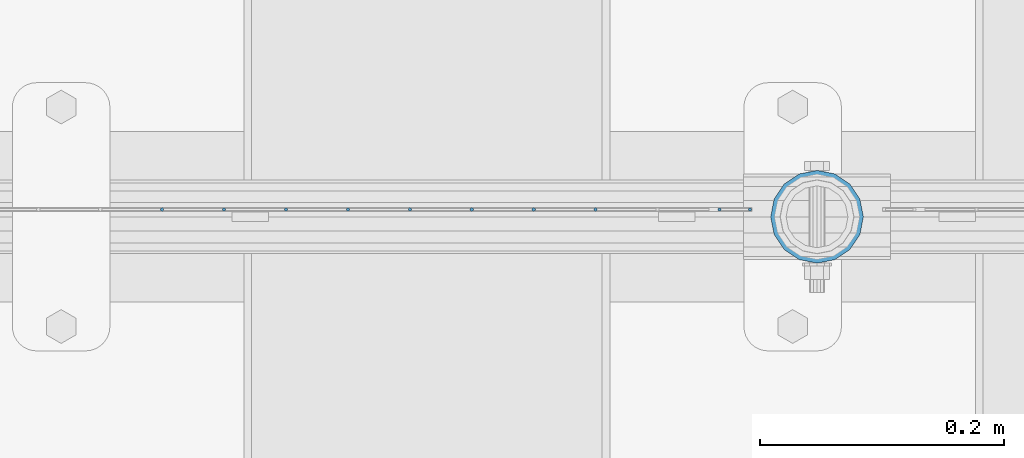
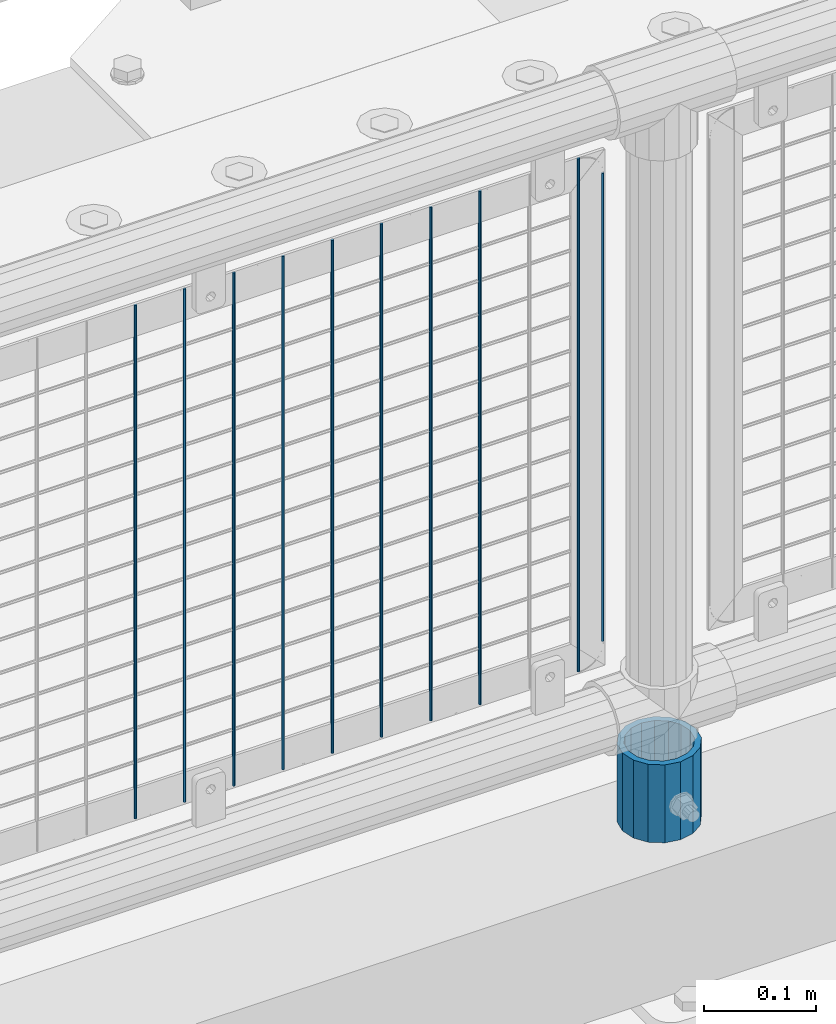
# One storey, part 73 of 242: 11 columns.
"""IFC2X3 building model written with IfcOpenShell, lengths in millimetres."""

import ifcopenshell
import ifcopenshell.guid

model = None  # the IFC model being written
_history = None  # IfcOwnerHistory: only IFC2X3 demands one
_inside = {}  # id of a spatial element -> (the spatial element, [elements in it])
_under = {}  # id of a project, library or spatial element -> (it, [spatial elements below it])
_declared = {}  # id of a project -> (the project, [libraries it declares])
_typed = {}  # id of a type object -> (the type object, [elements of that type])
_made_of = {}  # id of a material, layer set ... -> (it, [elements and type objects made of it])


def new_model(schema):
    """Start an empty IFC model of exactly this schema.

    Asked for "IFC4X3", IfcOpenShell would pick the latest addendum, in which some entities
    have other attributes; the version numbers below select the first issue.
    IFC2X3 requires an IfcOwnerHistory on every rooted entity: one is made here for all.
    """
    global model, _history
    if schema == "IFC4X3":
        model = ifcopenshell.file(schema_version=(4, 3, 0, 0))
    else:
        model = ifcopenshell.file(schema=schema)
    _inside.clear()
    _under.clear()
    _declared.clear()
    _typed.clear()
    _made_of.clear()
    _history = None
    if model.schema == "IFC2X3":
        org = make("IfcOrganization", Name="unknown")
        user = make(
            "IfcPersonAndOrganization",
            ThePerson=make("IfcPerson", FamilyName="unknown"),
            TheOrganization=org,
        )
        app = make(
            "IfcApplication",
            ApplicationDeveloper=org,
            Version="unknown",
            ApplicationFullName="unknown",
            ApplicationIdentifier="unknown",
        )
        _history = make(
            "IfcOwnerHistory",
            OwningUser=user,
            OwningApplication=app,
            ChangeAction="ADDED",
            CreationDate=0,
        )
    return model


def make(cls, **values):
    """One entity of the class cls with the attributes given. An attribute that is None is left unset."""
    return model.create_entity(
        cls, **{name: value for name, value in values.items() if value is not None}
    )


def rooted(cls, **values):
    """An entity with a GlobalId (a new one), such as an element, a storey or a relation."""
    return make(cls, GlobalId=ifcopenshell.guid.new(), OwnerHistory=_history, **values)


def si_unit(unit_type, name, prefix=None):
    """IfcSIUnit, for example si_unit("LENGTHUNIT", "METRE", prefix="MILLI")."""
    return make("IfcSIUnit", UnitType=unit_type, Prefix=prefix, Name=name)


def assignment(units):
    """IfcUnitAssignment: the units of a project."""
    return None if units is None else make("IfcUnitAssignment", Units=units)


def point(xyz):
    """IfcCartesianPoint."""
    return None if xyz is None else make("IfcCartesianPoint", Coordinates=xyz)


def direction(xyz):
    """IfcDirection."""
    return None if xyz is None else make("IfcDirection", DirectionRatios=xyz)


def frame(location, z_axis=None, x_axis=None):
    """IfcAxis2Placement3D, a coordinate frame: its origin and axes. An axis left out is left unset."""
    return make(
        "IfcAxis2Placement3D",
        Location=point(location),
        Axis=direction(z_axis),
        RefDirection=direction(x_axis),
    )


def origin_with_axes():
    """The frame at (0, 0, 0) with the z axis (0, 0, 1) and the x axis (1, 0, 0) written out."""
    return frame((0.0, 0.0, 0.0), z_axis=(0.0, 0.0, 1.0), x_axis=(1.0, 0.0, 0.0))


def place(relative_to, where):
    """IfcLocalPlacement: puts the frame where relative to a parent placement (None: the world)."""
    return make(
        "IfcLocalPlacement", PlacementRelTo=relative_to, RelativePlacement=where
    )


def context(
    kind, dimensions, precision=None, world=None, true_north=None, identifier=None
):
    """IfcGeometricRepresentationContext, for example the 3D "Model" context."""
    return make(
        "IfcGeometricRepresentationContext",
        ContextIdentifier=identifier,
        ContextType=kind,
        CoordinateSpaceDimension=dimensions,
        Precision=precision,
        WorldCoordinateSystem=world,
        TrueNorth=true_north,
    )


def subcontext(parent, identifier, kind, view, scale=None):
    """IfcGeometricRepresentationSubContext, for example "Body" below "Model"."""
    return make(
        "IfcGeometricRepresentationSubContext",
        ContextIdentifier=identifier,
        ContextType=kind,
        ParentContext=parent,
        TargetScale=scale,
        TargetView=view,
    )


def project(units=None, contexts=None):
    """IfcProject with its units and contexts."""
    return rooted(
        "IfcProject",
        Name="project",
        RepresentationContexts=contexts,
        UnitsInContext=assignment(units),
    )


def spatial(cls, under=None, at=None, **own):
    """A site, building, storey or space (cls), placed at a placement, below another one or the project."""
    s = rooted(cls, ObjectPlacement=at, **own)
    if under is not None:
        _under.setdefault(under.id(), (under, []))[1].append(s)
    return s


def faces_of(points, faces, orient=None, outer=None):
    """IfcFace entities. A face is a list of loops; a loop is a list of indices into points, from 0.

    orient and outer hold one flag for each loop. By default every Orientation is true, the
    first loop of a face is its IfcFaceOuterBound and the others are IfcFaceBound.
    """
    made = []
    for i, loops in enumerate(faces):
        bounds = []
        for j, loop in enumerate(loops):
            is_outer = j == 0 if outer is None else outer[i][j]
            bounds.append(
                make(
                    "IfcFaceOuterBound" if is_outer else "IfcFaceBound",
                    Bound=make("IfcPolyLoop", Polygon=[points[k] for k in loop]),
                    Orientation=True if orient is None else orient[i][j],
                )
            )
        made.append(make("IfcFace", Bounds=bounds))
    return made


def faceted_brep(points, faces, orient=None, outer=None, voids=None):
    """IfcFacetedBrep: a solid bounded by flat faces; with voids (closed shells), ...WithVoids."""
    shared = [point(p) for p in points]
    hull = make("IfcClosedShell", CfsFaces=faces_of(shared, faces, orient, outer))
    if voids is None:
        return make("IfcFacetedBrep", Outer=hull)
    return make(
        "IfcFacetedBrepWithVoids",
        Outer=hull,
        Voids=[
            make(cls, CfsFaces=faces_of(shared, fs, o, b)) for cls, fs, o, b in voids
        ],
    )


def shape(context_of_items, identifier, shape_type, items):
    """IfcShapeRepresentation: the items that make up one representation, for example the "Body"."""
    return make(
        "IfcShapeRepresentation",
        ContextOfItems=context_of_items,
        RepresentationIdentifier=identifier,
        RepresentationType=shape_type,
        Items=items,
    )


def material(Name=None, Category=None):
    """IfcMaterial."""
    return make("IfcMaterial", Name=Name, Category=Category)


def made_of(thing, what):
    """Note that an element or type object is made of a material, layer set ...; save() writes the relation."""
    if what is not None:
        _made_of.setdefault(what.id(), (what, []))[1].append(thing)
    return thing


def type_object(cls, material=None, **own):
    """A type object (cls), such as IfcWallType, which elements share."""
    return made_of(rooted(cls, **own), material)


def element(
    cls,
    number,
    at=None,
    inside=None,
    cuts=None,
    type_object=None,
    material=None,
    context=None,
    identifier="Body",
    shape_type=None,
    held_by="IfcProductDefinitionShape",
    body=None,
    shapes=None,
    **own,
):
    """One element of the class cls, such as IfcWall. Its Tag is "e" and its number.

    at: its placement. inside: the storey or other place that contains it. cuts: it is an
    opening in that element (IfcRelVoidsElement). A single representation is given by context,
    identifier, shape_type and body (its items); several are given by shapes. held_by: the class
    of the entity that holds the representations. save() writes the other relations.
    """
    e = rooted(cls, Tag="e%d" % number, ObjectPlacement=at, **own)
    if body is not None:
        shapes = [shape(context, identifier, shape_type, body)]
    if shapes is not None:
        e.Representation = make(held_by, Representations=shapes)
    if inside is not None:
        _inside.setdefault(inside.id(), (inside, []))[1].append(e)
    if cuts is not None:
        rooted(
            "IfcRelVoidsElement", RelatingBuildingElement=cuts, RelatedOpeningElement=e
        )
    if type_object is not None:
        _typed.setdefault(type_object.id(), (type_object, []))[1].append(e)
    return made_of(e, material)


def aggregate(whole, parts):
    """IfcRelAggregates: a whole, such as a stair, and the parts it consists of."""
    return rooted("IfcRelAggregates", RelatingObject=whole, RelatedObjects=parts)


def save(model, path):
    """Write the relations noted so far, then the file.

    IfcRelAggregates (storeys below a building ...), IfcRelContainedInSpatialStructure (elements
    in a storey), IfcRelDefinesByType, IfcRelAssociatesMaterial and IfcRelDeclares: one each for
    every whole, place, type object, material and project.
    """
    for whole, parts in _under.values():
        aggregate(whole, parts)
    for where, things in _inside.values():
        rooted(
            "IfcRelContainedInSpatialStructure",
            RelatedElements=things,
            RelatingStructure=where,
        )
    for kind, things in _typed.values():
        rooted("IfcRelDefinesByType", RelatedObjects=things, RelatingType=kind)
    for what, things in _made_of.values():
        rooted("IfcRelAssociatesMaterial", RelatedObjects=things, RelatingMaterial=what)
    for by, libraries in _declared.values():
        rooted("IfcRelDeclares", RelatingContext=by, RelatedDefinitions=libraries)
    model.write(path)


model = new_model("IFC2X3")

# Units and contexts
model_context = context("Model", 3, precision=1e-05, world=origin_with_axes())
body_context = subcontext(model_context, "Body", "Model", "MODEL_VIEW")
ifc_project = project(units=[si_unit("LENGTHUNIT", "METRE", prefix="MILLI"), si_unit("AREAUNIT", "SQUARE_METRE"), si_unit("VOLUMEUNIT", "CUBIC_METRE"), si_unit("MASSUNIT", "GRAM", prefix="KILO"), si_unit("TIMEUNIT", "SECOND"), si_unit("PLANEANGLEUNIT", "RADIAN"), si_unit("SOLIDANGLEUNIT", "STERADIAN"), si_unit("THERMODYNAMICTEMPERATUREUNIT", "DEGREE_CELSIUS"), si_unit("LUMINOUSINTENSITYUNIT", "LUMEN")], contexts=[model_context])

# Site, building, storey
site_placement = place(None, origin_with_axes())
site = spatial("IfcSite", under=ifc_project, at=site_placement, CompositionType="ELEMENT")
building_placement = place(site_placement, origin_with_axes())
building = spatial("IfcBuilding", under=site, at=building_placement, Name="Standard", CompositionType="ELEMENT")
storey_placement = place(building_placement, origin_with_axes())
storey = spatial("IfcBuildingStorey", under=building, at=storey_placement, Name="Undefined", CompositionType="ELEMENT", Elevation=0.0)

# Columns
ifc_material_1 = material(Name="Misc_Undefined")
column_type_1 = type_object("IfcColumnType", Name="D3", PredefinedType="NOTDEFINED")
for number, where, z_axis, x_axis in (
    (1, (-37111.589, -19329.5, 353.02), (-1.0, 0.0, 0.0), (0.0, 0.0, 1.0)),
    (2, (-37162.382, -19329.5, 353.02), (-1.0, 0.0, 0.0), (0.0, 0.0, 1.0)),
    (3, (-37213.175, -19329.5, 353.02), (-1.0, 0.0, 0.0), (0.0, 0.0, 1.0)),
    (4, (-37263.968, -19329.5, 353.02), (-1.0, 0.0, 0.0), (0.0, 0.0, 1.0)),
    (5, (-37314.761, -19329.5, 353.02), (-1.0, 0.0, 0.0), (0.0, 0.0, 1.0)),
    (6, (-37365.554, -19329.5, 353.02), (-1.0, 0.0, 0.0), (0.0, 0.0, 1.0)),
    (7, (-37010.003, -19329.5, 353.02), (-1.0, 0.0, 0.0), (0.0, 0.0, 1.0)),
    (8, (-37416.347, -19329.5, 353.02), (-1.0, 0.0, 0.0), (0.0, 0.0, 1.0)),
    (9, (-37467.14, -19329.5, 353.02), (-1.0, 0.0, 0.0), (0.0, 0.0, 1.0)),
):
    element("IfcColumn", number, at=place(storey_placement, frame(where, z_axis=z_axis, x_axis=x_axis)), inside=storey, type_object=column_type_1, material=ifc_material_1, ObjectType="D3", context=body_context, shape_type="Brep", body=[
        faceted_brep([(0.0, -1.50000000000364, 0.0), (-3.63797880709171e-12, -0.750000000003638, -1.29903810567669), (560.0, -0.75, -1.29903810567703), (560.0, -1.5, 0.0), (0.0, 0.749999999996362, -1.29903810567669), (560.0, 0.75, -1.29903810567703), (-3.63797880709171e-12, 1.49999999999636, 0.0), (560.0, 1.5, 0.0), (0.0, 0.749999999996362, 1.29903810567669), (560.0, 0.75, 1.29903810567703), (-3.63797880709171e-12, -0.750000000003638, 1.29903810567669), (560.0, -0.75, 1.29903810567703)], [[[0, 1, 2, 3]], [[1, 4, 5, 2]], [[4, 6, 7, 5]], [[6, 8, 9, 7]], [[8, 10, 11, 9]], [[10, 0, 3, 11]], [[5, 7, 9, 11, 3, 2]], [[10, 8, 6, 4, 1, 0]]]),
    ])
column_1_placement = place(storey_placement, frame((-36985.0, -19329.5, 378.02), z_axis=(-1.0, 0.0, 0.0), x_axis=(0.0, 0.0, 1.0)))
element("IfcColumn", 10, at=column_1_placement, inside=storey, type_object=column_type_1, material=ifc_material_1, ObjectType="D3", context=body_context, shape_type="Brep", body=[
    faceted_brep([(0.0, -1.50000000000364, 0.0), (-3.63797880709171e-12, -0.750000000003638, -1.29903810567669), (510.0, -0.75, -1.29903810567703), (510.0, -1.5, 0.0), (0.0, 0.749999999996362, -1.29903810567669), (510.0, 0.75, -1.29903810567703), (-3.63797880709171e-12, 1.49999999999636, 0.0), (510.0, 1.5, 0.0), (0.0, 0.749999999996362, 1.29903810567669), (510.0, 0.75, 1.29903810567703), (-3.63797880709171e-12, -0.750000000003638, 1.29903810567669), (510.0, -0.75, 1.29903810567703)], [[[0, 1, 2, 3]], [[1, 4, 5, 2]], [[4, 6, 7, 5]], [[6, 8, 9, 7]], [[8, 10, 11, 9]], [[10, 0, 3, 11]], [[5, 7, 9, 11, 3, 2]], [[10, 8, 6, 4, 1, 0]]]),
])
ifc_material_2 = material()
column_type_2 = type_object("IfcColumnType", PredefinedType="NOTDEFINED")
column_2_placement = place(storey_placement, frame((-36930.0, -19335.5, 168.02), z_axis=(0.0, 1.0, 0.0), x_axis=(0.0, 0.0, 1.0)))
element("IfcColumn", 11, at=column_2_placement, inside=storey, type_object=column_type_2, material=ifc_material_2, context=body_context, shape_type="Brep", body=[
    faceted_brep([(0.0, -31.75, 0.0), (0.0, -29.3331751572332, 12.1501989775934), (85.0, -29.3331751572332, 12.1501989775934), (85.0, -31.75, 0.0), (0.0, -22.4506403026717, 22.4506403026717), (85.0, -22.4506403026717, 22.4506403026717), (0.0, -12.1501989775934, 29.3331751572332), (85.0, -12.1501989775934, 29.3331751572332), (0.0, 0.0, 31.75), (85.0, 0.0, 31.75), (0.0, 12.1501989775934, 29.3331751572332), (85.0, 12.1501989775934, 29.3331751572332), (0.0, 22.4506403026717, 22.4506403026717), (85.0, 22.4506403026717, 22.4506403026717), (0.0, 29.3331751572332, 12.1501989775934), (85.0, 29.3331751572332, 12.1501989775934), (0.0, 31.75, 0.0), (85.0, 31.75, 0.0), (0.0, 29.3331751572332, -12.1501989775934), (85.0, 29.3331751572332, -12.1501989775934), (0.0, 22.4506403026717, -22.4506403026717), (85.0, 22.4506403026717, -22.4506403026717), (0.0, 12.1501989775934, -29.3331751572332), (85.0, 12.1501989775934, -29.3331751572332), (0.0, 0.0, -31.75), (85.0, 0.0, -31.75), (0.0, -12.1501989775934, -29.3331751572332), (85.0, -12.1501989775934, -29.3331751572332), (0.0, -22.4506403026717, -22.4506403026717), (85.0, -22.4506403026717, -22.4506403026717), (0.0, -29.3331751572332, -12.1501989775934), (85.0, -29.3331751572332, -12.1501989775934), (0.0, -38.0499999999993, 0.0), (0.0, -35.1536162120537, -14.5611046014928), (85.0, -35.1536162120537, -14.5611046014928), (85.0, -38.0499999999993, 0.0), (0.0, -26.9054130241493, -26.9054130241493), (85.0, -26.9054130241493, -26.9054130241493), (0.0, -14.5611046014928, -35.1536162120537), (85.0, -14.5611046014928, -35.1536162120537), (0.0, 0.0, -38.0499999999993), (85.0, 0.0, -38.0499999999993), (0.0, 14.5611046014928, -35.1536162120537), (85.0, 14.5611046014928, -35.1536162120537), (0.0, 26.9054130241493, -26.9054130241493), (85.0, 26.9054130241493, -26.9054130241493), (0.0, 35.1536162120537, -14.5611046014928), (85.0, 35.1536162120537, -14.5611046014928), (0.0, 38.0499999999993, 0.0), (85.0, 38.0499999999993, 0.0), (0.0, 35.1536162120537, 14.5611046014928), (85.0, 35.1536162120537, 14.5611046014928), (0.0, 26.9054130241493, 26.9054130241493), (85.0, 26.9054130241493, 26.9054130241493), (0.0, 14.5611046014928, 35.1536162120537), (85.0, 14.5611046014928, 35.1536162120537), (0.0, 0.0, 38.0499999999993), (85.0, 0.0, 38.0499999999993), (0.0, -14.5611046014928, 35.1536162120537), (85.0, -14.5611046014928, 35.1536162120537), (0.0, -26.9054130241493, 26.9054130241493), (85.0, -26.9054130241493, 26.9054130241493), (0.0, -35.1536162120537, 14.5611046014928), (85.0, -35.1536162120537, 14.5611046014928)], [[[0, 1, 2, 3]], [[1, 4, 5, 2]], [[4, 6, 7, 5]], [[6, 8, 9, 7]], [[8, 10, 11, 9]], [[10, 12, 13, 11]], [[12, 14, 15, 13]], [[14, 16, 17, 15]], [[16, 18, 19, 17]], [[18, 20, 21, 19]], [[20, 22, 23, 21]], [[22, 24, 25, 23]], [[24, 26, 27, 25]], [[26, 28, 29, 27]], [[28, 30, 31, 29]], [[30, 0, 3, 31]], [[32, 33, 34, 35]], [[33, 36, 37, 34]], [[36, 38, 39, 37]], [[38, 40, 41, 39]], [[40, 42, 43, 41]], [[42, 44, 45, 43]], [[44, 46, 47, 45]], [[46, 48, 49, 47]], [[48, 50, 51, 49]], [[50, 52, 53, 51]], [[52, 54, 55, 53]], [[54, 56, 57, 55]], [[56, 58, 59, 57]], [[58, 60, 61, 59]], [[60, 62, 63, 61]], [[62, 32, 35, 63]], [[37, 39, 41, 43, 45, 47, 49, 51, 53, 55, 57, 59, 61, 63, 35, 34], [5, 7, 9, 11, 13, 15, 17, 19, 21, 23, 25, 27, 29, 31, 3, 2]], [[62, 60, 58, 56, 54, 52, 50, 48, 46, 44, 42, 40, 38, 36, 33, 32], [30, 28, 26, 24, 22, 20, 18, 16, 14, 12, 10, 8, 6, 4, 1, 0]]]),
])

save(model, "model.ifc")
